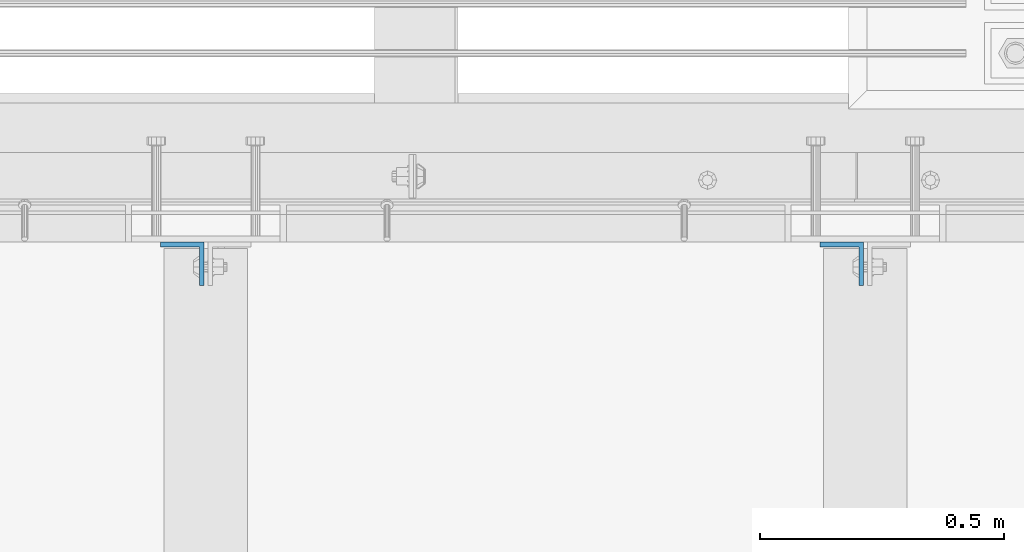
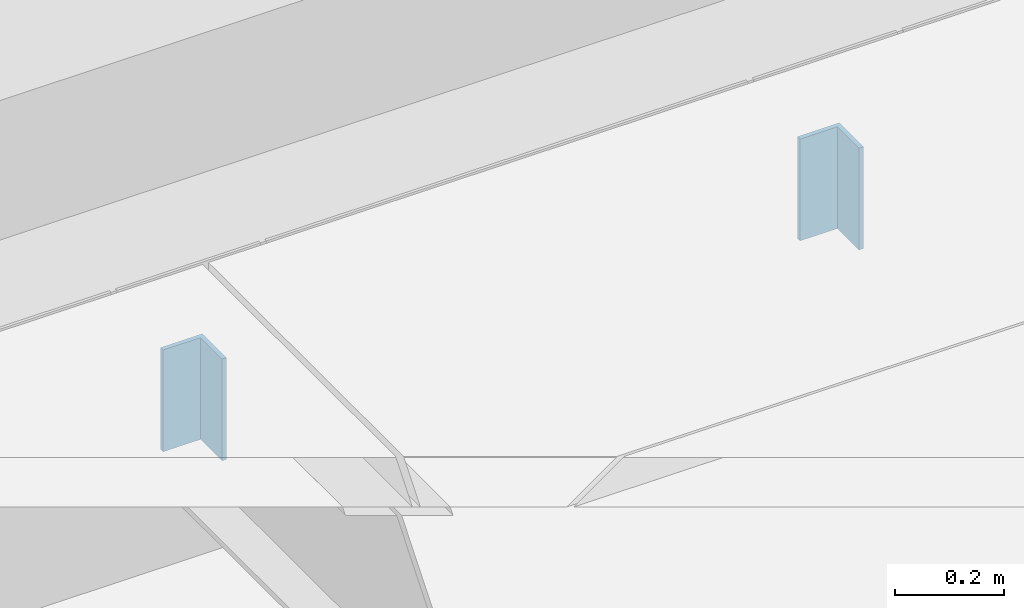
# One storey, part 1482 of 3843: 2 columns, 2 elements without a shape of their own.
"""IFC2X3 building model written with IfcOpenShell, lengths in millimetres."""

from ifc_helpers import new_model, si_unit, frame, origin_with_axes, place, context, subcontext, project, spatial, faceted_brep, material, type_object, element, aggregate, save


model = new_model("IFC2X3")

# Units and contexts
model_context = context("Model", 3, precision=1e-05, world=origin_with_axes())
body_context = subcontext(model_context, "Body", "Model", "MODEL_VIEW")
ifc_project = project(units=[si_unit("LENGTHUNIT", "METRE", prefix="MILLI"), si_unit("AREAUNIT", "SQUARE_METRE"), si_unit("VOLUMEUNIT", "CUBIC_METRE"), si_unit("MASSUNIT", "GRAM", prefix="KILO"), si_unit("TIMEUNIT", "SECOND"), si_unit("PLANEANGLEUNIT", "RADIAN"), si_unit("SOLIDANGLEUNIT", "STERADIAN"), si_unit("THERMODYNAMICTEMPERATUREUNIT", "DEGREE_CELSIUS"), si_unit("LUMINOUSINTENSITYUNIT", "LUMEN")], contexts=[model_context])

# Site, building, storey
site_placement = place(None, origin_with_axes())
site = spatial("IfcSite", under=ifc_project, at=site_placement, CompositionType="ELEMENT")
building_placement = place(site_placement, origin_with_axes())
building = spatial("IfcBuilding", under=site, at=building_placement, Name="Undefined", CompositionType="ELEMENT")
storey_placement = place(building_placement, origin_with_axes())
storey = spatial("IfcBuildingStorey", under=building, at=storey_placement, Name="Undefined", CompositionType="ELEMENT", Elevation=0.0)

# Assembly, column
assembly_1_placement = place(storey_placement, origin_with_axes())
assembly_1 = element("IfcElementAssembly", 1, at=assembly_1_placement, inside=storey, Name="BEAM", AssemblyPlace="NOTDEFINED", PredefinedType="RIGID_FRAME")
ifc_material = material(Name="STEEL/A36")
column_type = type_object("IfcColumnType", Name="L3-1/2X3-1/2X3/8", PredefinedType="NOTDEFINED")
column_1_placement = place(assembly_1_placement, frame((48132.20625, 24879.2999969483, 30137.1), z_axis=(-1.0, 0.0, 0.0), x_axis=(0.0, 0.0, 1.0)))
column_1 = element("IfcColumn", 2, at=column_1_placement, type_object=column_type, material=ifc_material, Name="ANGLE", ObjectType="L3-1/2X3-1/2X3/8", context=body_context, shape_type="Brep", body=[
    faceted_brep([(-3.63797880709171e-12, 44.4499999999971, -44.4500000000007), (-3.63797880709171e-12, 44.4499999999971, 44.4500000000007), (228.600000000006, 44.4499999999971, 44.4500000000007), (228.600000000006, 44.4499999999971, -44.4500000000007), (0.0, 34.9250000000029, 44.4500000000007), (228.600000000006, 34.9250000000029, 44.4500000000007), (0.0, 34.9250000000029, -34.9250000000029), (228.600000000006, 34.9250000000029, -34.9249999999993), (0.0, -44.4499999999971, -34.9249999999993), (228.600000000006, -44.4499999999971, -34.9249999999993), (3.63797880709171e-12, -44.4499999999971, -44.4500000000007), (228.600000000006, -44.4499999999971, -44.4500000000007)], [[[0, 1, 2, 3]], [[1, 4, 5, 2]], [[4, 6, 7, 5]], [[6, 8, 9, 7]], [[8, 10, 11, 9]], [[10, 0, 3, 11]], [[5, 7, 9, 11, 3, 2]], [[10, 8, 6, 4, 1, 0]]]),
])
aggregate(assembly_1, [column_1])

assembly_2_placement = place(storey_placement, origin_with_axes())
assembly_2 = element("IfcElementAssembly", 3, at=assembly_2_placement, inside=storey, Name="BEAM", AssemblyPlace="NOTDEFINED", PredefinedType="RIGID_FRAME")
column_2_placement = place(assembly_2_placement, frame((46779.65625, 24879.2999969483, 30137.1), z_axis=(-1.0, 0.0, 0.0), x_axis=(0.0, 0.0, 1.0)))
column_2 = element("IfcColumn", 4, at=column_2_placement, type_object=column_type, material=ifc_material, Name="ANGLE", ObjectType="L3-1/2X3-1/2X3/8", context=body_context, shape_type="Brep", body=[
    faceted_brep([(-3.63797880709171e-12, 44.4499999999971, -44.4500000000007), (-3.63797880709171e-12, 44.4499999999971, 44.4500000000007), (228.600000000006, 44.4499999999971, 44.4500000000007), (228.600000000006, 44.4499999999971, -44.4500000000007), (0.0, 34.9250000000029, 44.4500000000007), (228.600000000006, 34.9250000000029, 44.4500000000007), (0.0, 34.9250000000029, -34.9250000000029), (228.600000000006, 34.9250000000029, -34.9249999999993), (0.0, -44.4499999999971, -34.9249999999993), (228.600000000006, -44.4499999999971, -34.9249999999993), (3.63797880709171e-12, -44.4499999999971, -44.4500000000007), (228.600000000006, -44.4499999999971, -44.4500000000007)], [[[0, 1, 2, 3]], [[1, 4, 5, 2]], [[4, 6, 7, 5]], [[6, 8, 9, 7]], [[8, 10, 11, 9]], [[10, 0, 3, 11]], [[5, 7, 9, 11, 3, 2]], [[10, 8, 6, 4, 1, 0]]]),
])
aggregate(assembly_2, [column_2])

save(model, "model.ifc")
